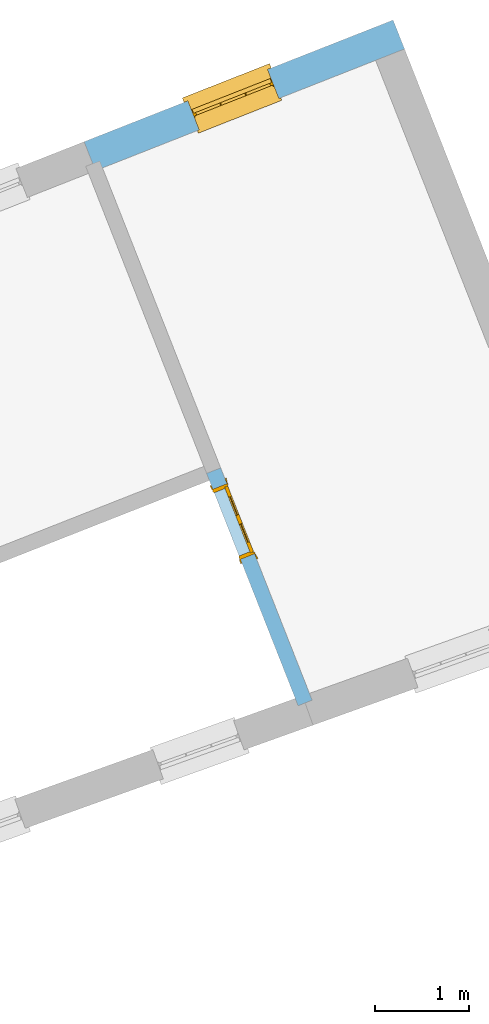
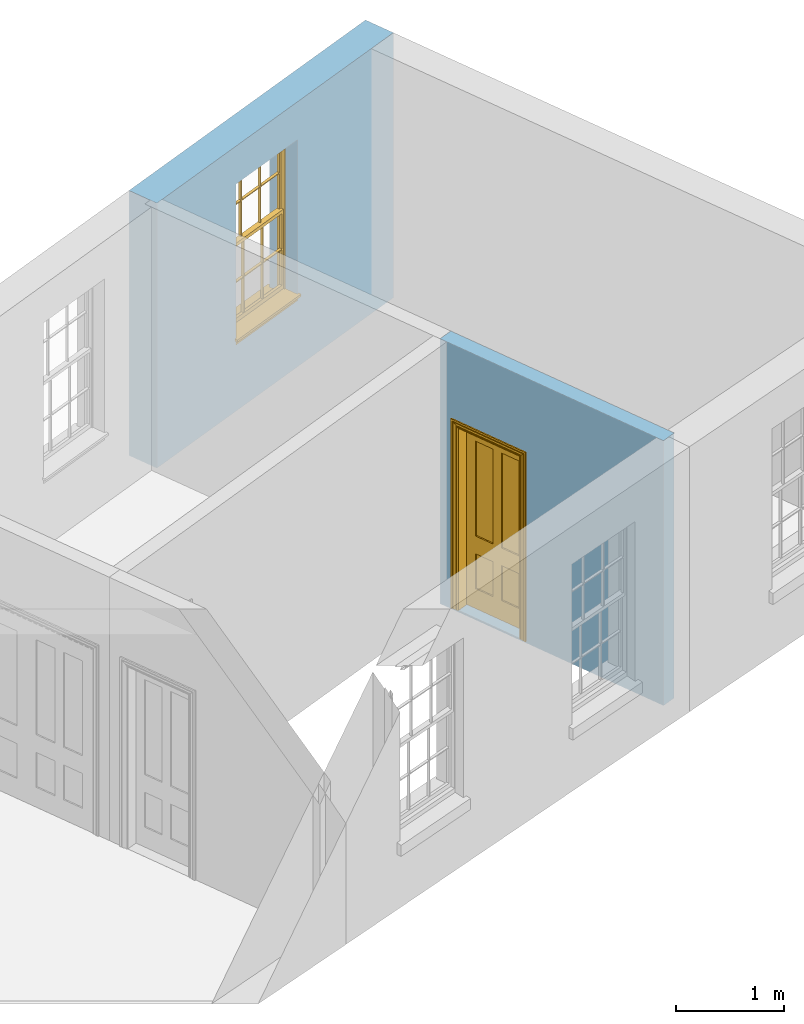
# One storey, part 6 of 6: 1 door, 1 window, 2 openings, plus 2 elements that do not belong to this part.
"""IFC2X3 building model written with IfcOpenShell, lengths in metres."""

from ifc_helpers import new_model, si_unit, frame, origin, place, context, subcontext, project, spatial, polyline, outline, extrude, faceted_brep, material, layer, layer_set, layer_usage, element, fill, save


model = new_model("IFC2X3")

# Units and contexts
model_context = context("Model", 3, world=origin())
body_context = subcontext(model_context, "Body", "Model", "MODEL_VIEW")
ifc_project = project(units=[si_unit("PLANEANGLEUNIT", "RADIAN"), si_unit("MASSUNIT", "GRAM", prefix="KILO"), si_unit("FORCEUNIT", "NEWTON", prefix="KILO"), si_unit("LENGTHUNIT", "METRE")], contexts=[model_context])

# Site, building, storey
site_placement = place(None, origin())
site = spatial("IfcSite", under=ifc_project, at=site_placement, CompositionType="ELEMENT")
building_placement = place(None, origin())
building = spatial("IfcBuilding", under=site, at=building_placement, Name="Building plot-4", CompositionType="ELEMENT")
storey_placement = place(None, frame((0.0, 0.0, 6.45)))
storey = spatial("IfcBuildingStorey", under=building, at=storey_placement, Name="Floor 1", CompositionType="ELEMENT", Elevation=6.45)

# Wall, opening, window
ifc_material_1 = material(Name="Masonry")
ifc_layer_1 = layer(ifc_material_1, 0.33, ventilated=False)
ifc_layer_set_1 = layer_set([ifc_layer_1], Name="My Wall")
ifc_layer_usage_1 = layer_usage(ifc_layer_set_1, "AXIS2", "NEGATIVE", 0.08)
wall_1_placement = place(storey_placement, origin())
wall_1 = element("IfcWallStandardCase", 1, at=wall_1_placement, inside=storey, material=ifc_layer_usage_1, Name="exterior", context=body_context, shape_type="SweptSolid", body=[
    extrude(outline(polyline([(55.3138387008242, 55.0638365529384), (55.192917321505, 55.3708838131828), (51.9157706887258, 54.0802776349957), (52.0366920680449, 53.7732303747513), (55.3138387008242, 55.0638365529384)])), origin(), (0.0, 0.0, 1.0), 3.0),
])
opening_1_placement = place(storey_placement, frame((0.0, 0.0, 0.75)))
opening_1 = element("IfcOpeningElement", 2, at=opening_1_placement, cuts=wall_1, Name="Opening", ObjectType="Opening", context=body_context, shape_type="SweptSolid", body=[
    extrude(outline(polyline([(53.8613912653598, 54.8465021034084), (53.0146851840799, 54.5130522392253), (53.1356065633991, 54.2060049789809), (53.9823126446789, 54.539454843164), (53.8613912653598, 54.8465021034084)])), origin(), (0.0, 0.0, 1.0), 1.82),
])
window_placement = place(storey_placement, frame((53.9529983709046, 54.6138905426172, 0.75), z_axis=(0.0, 0.0, 1.0), x_axis=(-0.846706081279848, -0.333449864183102, 0.0)))
window = element("IfcWindow", 3, at=window_placement, inside=storey, Name="bedroom outside window", OverallHeight=1.82, OverallWidth=0.91, context=body_context, shape_type="Brep", held_by="IfcProductRepresentation", body=[
    faceted_brep([(0.033125, -0.105, 0.975209), (0.01, -0.105, 0.975209), (0.033125, -0.105, 1.376042), (0.876875, -0.105, 0.975209), (0.876875, -0.105, 1.376042), (0.9, -0.105, 0.975209), (0.876875, -0.105, 1.386042), (0.876875, -0.105, 1.786875), (0.9, -0.105, 1.81), (0.033125, -0.105, 1.786875), (0.033125, -0.105, 1.386042), (0.01, -0.105, 1.81), (0.876875, -0.135, 1.376042), (0.876875, -0.135, 0.975209), (0.9, -0.135, 0.937083), (0.033125, -0.135, 1.786875), (0.01, -0.135, 1.81), (0.033125, -0.135, 1.386042), (0.01, -0.135, 0.937083), (0.033125, -0.135, 0.975209), (0.033125, -0.135, 1.376042), (0.876875, -0.135, 1.786875), (0.876875, -0.135, 1.386042), (0.9, -0.135, 1.81), (0.033125, -0.105, 0.937083), (0.01, -0.105, 0.937083), (0.033125, -0.105, 0.53625), (0.876875, -0.105, 0.937083), (0.876875, -0.105, 0.53625), (0.9, -0.105, 0.937083), (0.876875, -0.105, 0.52625), (0.876875, -0.105, 0.125417), (0.9, -0.105, 0.077167), (0.033125, -0.105, 0.125417), (0.033125, -0.105, 0.52625), (0.01, -0.105, 0.077167), (-0.0425, -0.25, 0.01), (-0.0425, -0.3, 0.001667), (0.0, -0.25, 0.01), (0.9525, -0.25, 0.01), (0.91, -0.25, 0.01), (0.9525, -0.3, 0.001667), (-0.02, 0.08, 0.077167), (0.0, 0.08, 0.077167), (-0.02, 0.11, 0.077167), (0.0, -0.06, 0.077167), (0.01, -0.06, 0.077167), (0.91, -0.06, 0.077167), (0.91, 0.08, 0.077167), (0.9, -0.06, 0.077167), (0.93, 0.08, 0.077167), (0.93, 0.11, 0.077167), (0.01, -0.075, 0.975209), (0.9, -0.075, 0.975209), (0.876875, -0.075, 0.125417), (0.876875, -0.075, 0.52625), (0.9, -0.075, 0.077167), (0.876875, -0.075, 0.53625), (0.876875, -0.075, 0.937083), (0.033125, -0.075, 0.125417), (0.01, -0.075, 0.077167), (0.033125, -0.075, 0.52625), (0.033125, -0.075, 0.937083), (0.033125, -0.075, 0.53625), (-0.02, 0.08, 0.052167), (-0.02, 0.11, 0.052167), (0.93, 0.11, 0.052167), (0.93, 0.08, 0.052167), (0.91, 0.08, 0.052167), (0.0, 0.08, 0.052167), (0.91, -0.15, 0.026667), (0.0, -0.15, 0.026667), (-0.0425, -0.3, -0.123333), (0.9525, -0.3, -0.123333), (-0.0425, -0.25, -0.123333), (0.9525, -0.25, -0.123333), (0.01, -0.06, 1.81), (0.9, -0.06, 1.81), (0.0, -0.06, 1.82), (0.91, -0.06, 1.82), (0.01, -0.15, 0.077167), (0.9, -0.15, 0.077167), (0.592292, -0.105, 0.125417), (0.592292, -0.075, 0.125417), (0.317708, -0.075, 0.125417), (0.317708, -0.105, 0.125417), (0.592292, -0.105, 0.53625), (0.317708, -0.105, 0.53625), (0.317708, -0.105, 0.52625), (0.592292, -0.105, 0.52625), (0.592292, -0.075, 0.53625), (0.317708, -0.075, 0.53625), (0.592292, -0.135, 1.386042), (0.592292, -0.105, 1.386042), (0.317708, -0.105, 1.386042), (0.317708, -0.135, 1.386042), (0.317708, -0.135, 1.376042), (0.592292, -0.135, 1.376042), (0.317708, -0.105, 1.376042), (0.592292, -0.105, 1.376042), (0.602292, -0.135, 1.376042), (0.592292, -0.135, 0.975209), (0.602292, -0.135, 0.975209), (0.602292, -0.105, 0.975209), (0.592292, -0.105, 0.975209), (0.602292, -0.105, 1.376042), (0.602292, -0.075, 0.53625), (0.602292, -0.105, 0.53625), (0.317708, -0.075, 0.52625), (0.307708, -0.075, 0.125417), (0.307708, -0.075, 0.52625), (0.602292, -0.075, 0.52625), (0.602292, -0.075, 0.125417), (0.592292, -0.075, 0.52625), (0.307708, -0.075, 0.53625), (0.317708, -0.075, 0.937083), (0.307708, -0.075, 0.937083), (0.602292, -0.075, 0.937083), (0.592292, -0.075, 0.937083), (0.307708, -0.105, 0.52625), (0.307708, -0.105, 0.125417), (0.307708, -0.105, 0.53625), (0.307708, -0.105, 0.937083), (0.592292, -0.105, 0.937083), (0.317708, -0.105, 0.937083), (0.602292, -0.105, 0.937083), (0.602292, -0.105, 0.52625), (0.602292, -0.105, 0.125417), (0.307708, -0.135, 1.386042), (0.307708, -0.135, 1.376042), (0.307708, -0.135, 0.975209), (0.317708, -0.135, 0.975209), (0.317708, -0.135, 1.786875), (0.307708, -0.135, 1.786875), (0.602292, -0.135, 1.786875), (0.592292, -0.135, 1.786875), (0.602292, -0.135, 1.386042), (0.602292, -0.105, 1.386042), (0.307708, -0.105, 1.386042), (0.307708, -0.105, 1.786875), (0.317708, -0.105, 1.786875), (0.592292, -0.105, 1.786875), (0.602292, -0.105, 1.786875), (0.307708, -0.105, 1.376042), (0.317708, -0.105, 0.975209), (0.307708, -0.105, 0.975209), (0.91, -0.15, 1.82), (0.9, -0.15, 1.81), (0.01, -0.15, 1.81), (0.0, -0.15, 1.82), (0.91, -0.25, 0.0), (0.0, -0.25, 0.0), (0.91, 0.08, 0.0), (0.0, 0.08, 0.0)], [[[0, 1, 2]], [[3, 4, 5]], [[6, 7, 8]], [[9, 10, 11]], [[12, 13, 14]], [[15, 16, 17]], [[18, 19, 20]], [[21, 22, 23]], [[24, 25, 26]], [[27, 28, 29]], [[30, 31, 32]], [[33, 34, 35]], [[14, 27, 29]], [[25, 24, 18]], [[36, 37, 38]], [[39, 40, 41]], [[42, 43, 44]], [[45, 46, 43]], [[47, 48, 49]], [[50, 51, 48]], [[1, 0, 52]], [[5, 53, 3]], [[54, 55, 56]], [[57, 58, 53]], [[59, 60, 61]], [[62, 63, 52]], [[48, 43, 46, 49]], [[51, 44, 43, 48]], [[64, 42, 44, 65]], [[65, 44, 51, 66]], [[66, 51, 50, 67]], [[65, 66, 68, 69]], [[60, 56, 49, 46]], [[70, 71, 38, 40]], [[37, 41, 40, 38]], [[37, 72, 73, 41]], [[74, 75, 73, 72]], [[8, 11, 76, 77]], [[76, 78, 79, 77]], [[32, 35, 80, 81]], [[81, 80, 71, 70]], [[82, 83, 84, 85]], [[86, 87, 88, 89]], [[86, 90, 91, 87]], [[92, 93, 94, 95]], [[92, 95, 96, 97]], [[96, 98, 99, 97]], [[100, 97, 101, 102]], [[103, 104, 99, 105]], [[97, 99, 104, 101]], [[102, 103, 105, 100]], [[28, 57, 106, 107]], [[108, 84, 109, 110]], [[111, 112, 83, 113]], [[114, 110, 61, 63]], [[90, 113, 108, 91]], [[115, 91, 114, 116]], [[117, 106, 90, 118]], [[111, 106, 57, 55]], [[119, 110, 109, 120]], [[34, 61, 110, 119]], [[89, 113, 83, 82]], [[88, 108, 113, 89]], [[85, 84, 108, 88]], [[121, 114, 63, 26]], [[122, 116, 114, 121]], [[123, 118, 90, 86]], [[87, 91, 115, 124]], [[107, 106, 117, 125]], [[126, 111, 55, 30]], [[127, 112, 111, 126]], [[126, 30, 28, 107]], [[88, 119, 120, 85]], [[126, 89, 82, 127]], [[125, 123, 86, 107]], [[121, 26, 34, 119]], [[124, 122, 121, 87]], [[128, 17, 20, 129]], [[96, 129, 130, 131]], [[132, 133, 128, 95]], [[134, 135, 92, 136]], [[100, 12, 22, 136]], [[137, 6, 4, 105]], [[94, 138, 139, 140]], [[137, 93, 141, 142]], [[99, 98, 94, 93]], [[143, 2, 10, 138]], [[144, 145, 143, 98]], [[129, 143, 145, 130]], [[20, 2, 143, 129]], [[131, 144, 98, 96]], [[128, 138, 10, 17]], [[133, 139, 138, 128]], [[135, 141, 93, 92]], [[95, 94, 140, 132]], [[22, 6, 137, 136]], [[136, 137, 142, 134]], [[100, 105, 4, 12]], [[107, 86, 89, 126]], [[106, 111, 113, 90]], [[91, 108, 110, 114]], [[87, 121, 119, 88]], [[97, 100, 136, 92]], [[129, 96, 95, 128]], [[98, 143, 138, 94]], [[105, 99, 93, 137]], [[131, 101, 104, 144]], [[124, 115, 118, 123]], [[132, 140, 141, 135]], [[120, 109, 59, 33]], [[15, 9, 139, 133]], [[134, 142, 7, 21]], [[31, 54, 112, 127]], [[36, 74, 72, 37]], [[39, 41, 73, 75]], [[18, 14, 101, 131]], [[23, 16, 132, 135]], [[83, 56, 60, 84]], [[52, 53, 118, 115]], [[53, 52, 144, 104]], [[11, 8, 141, 140]], [[14, 18, 124, 123]], [[2, 1, 11, 10]], [[8, 5, 4, 6]], [[57, 53, 56, 55]], [[60, 52, 63, 61]], [[26, 25, 35, 34]], [[32, 29, 28, 30]], [[14, 23, 22, 12]], [[18, 20, 17, 16]], [[19, 0, 2, 20]], [[17, 10, 9, 15]], [[12, 4, 3, 13]], [[21, 7, 6, 22]], [[27, 58, 57, 28]], [[30, 55, 54, 31]], [[33, 59, 61, 34]], [[26, 63, 62, 24]], [[5, 8, 77, 53]], [[76, 11, 1, 52]], [[46, 45, 78, 76]], [[49, 77, 79, 47]], [[70, 146, 147, 81]], [[71, 80, 148, 149]], [[19, 130, 145, 0]], [[102, 13, 3, 103]], [[116, 122, 24, 62]], [[29, 32, 81, 14]], [[80, 35, 25, 18]], [[60, 46, 76, 52]], [[77, 49, 56, 53]], [[23, 14, 81, 147]], [[16, 148, 80, 18]], [[35, 85, 120]], [[120, 33, 35]], [[127, 82, 32]], [[32, 31, 127]], [[32, 82, 85, 35]], [[102, 101, 14]], [[14, 13, 102]], [[18, 131, 130]], [[130, 19, 18]], [[134, 21, 23]], [[23, 135, 134]], [[16, 15, 133]], [[133, 132, 16]], [[11, 140, 139]], [[139, 9, 11]], [[142, 141, 8]], [[8, 7, 142]], [[23, 147, 148, 16]], [[146, 149, 148, 147]], [[52, 115, 116]], [[116, 62, 52]], [[118, 53, 117]], [[58, 117, 53]], [[27, 125, 117, 58]], [[56, 83, 112]], [[112, 54, 56]], [[109, 84, 60]], [[60, 59, 109]], [[125, 27, 14]], [[14, 123, 125]], [[122, 124, 18]], [[18, 24, 122]], [[145, 144, 52]], [[52, 0, 145]], [[103, 3, 53]], [[53, 104, 103]], [[79, 78, 149, 146]], [[78, 45, 71, 149]], [[146, 70, 47, 79]], [[150, 75, 74, 151]], [[68, 66, 67]], [[48, 68, 67, 50]], [[69, 64, 65]], [[42, 64, 69, 43]], [[69, 68, 152, 153]], [[70, 68, 48, 47]], [[150, 152, 68, 70]], [[43, 69, 71, 45]], [[69, 153, 151, 71]], [[152, 150, 151, 153]], [[38, 151, 74, 36]], [[71, 151, 38]], [[39, 75, 150, 40]], [[40, 150, 70]]]),
])
fill(opening_1, window)

# Wall, opening, door
ifc_material_2 = material(Name="Masonry")
ifc_layer_2 = layer(ifc_material_2, 0.16, ventilated=False)
ifc_layer_set_2 = layer_set([ifc_layer_2], Name="My Wall")
ifc_layer_usage_2 = layer_usage(ifc_layer_set_2, "AXIS2", "NEGATIVE", 0.08)
wall_2_placement = place(storey_placement, origin())
wall_2 = element("IfcWallStandardCase", 4, at=wall_2_placement, inside=storey, material=ifc_layer_usage_2, Name="interior", context=body_context, shape_type="SweptSolid", body=[
    extrude(outline(polyline([(53.3639971862187, 50.6212203481571), (53.2151257873123, 50.5625918006085), (54.1850919906856, 48.0996239867093), (54.333963389592, 48.1582525342579), (53.3639971862187, 50.6212203481571)])), origin(), (0.0, 0.0, 1.0), 3.0),
])
opening_2_placement = place(storey_placement, frame((0.0, 0.0, 0.0199999999999996)))
opening_2 = element("IfcOpeningElement", 5, at=opening_2_placement, cuts=wall_2, Name="Opening", ObjectType="Opening", context=body_context, shape_type="SweptSolid", body=[
    extrude(outline(polyline([(53.2810829033046, 50.3951114768388), (53.574225641048, 49.6507544823071), (53.7230970399543, 49.7093830298558), (53.4299543022109, 50.4537400243875), (53.2810829033046, 50.3951114768388)])), origin(), (0.0, 0.0, 1.0), 2.1),
])
door_placement = place(storey_placement, frame((53.3555186027578, 50.4244257506132, 0.0199999999999996), z_axis=(0.0, 0.0, 1.0), x_axis=(0.293142737743402, -0.744356994531721, 0.0)))
door = element("IfcDoor", 6, at=door_placement, inside=storey, Name="bedroom inside door", OverallHeight=2.1, OverallWidth=0.8, context=body_context, shape_type="Brep", held_by="IfcProductRepresentation", body=[
    faceted_brep([(0.773, 0.08, 1.895), (0.66, 0.08, 1.895), (0.66, 0.08, 2.073), (0.773, 0.08, 2.073), (0.773, 0.08, 0.82), (0.66, 0.08, 0.82), (0.45, 0.08, 1.895), (0.45, 0.08, 2.073), (0.773, 0.08, 0.62), (0.66, 0.08, 0.62), (0.66, 0.065, 0.82), (0.66, 0.065, 1.895), (0.45, 0.065, 1.895), (0.35, 0.08, 1.895), (0.35, 0.08, 2.073), (0.773, 0.08, 0.225), (0.66, 0.08, 0.225), (0.45, 0.08, 0.62), (0.45, 0.08, 0.82), (0.45, 0.065, 0.82), (0.35, 0.08, 0.82), (0.14, 0.08, 2.073), (0.14, 0.08, 1.895), (0.773, 0.08, 0.0), (0.66, 0.08, 0.0), (0.66, 0.065, 0.225), (0.66, 0.065, 0.62), (0.45, 0.065, 0.62), (0.35, 0.08, 0.62), (0.35, 0.065, 0.82), (0.35, 0.065, 1.895), (0.14, 0.065, 1.895), (0.027, 0.08, 2.073), (0.027, 0.08, 1.895), (0.773, 0.042, 0.0), (0.66, 0.042, 0.0), (0.45, 0.08, 0.0), (0.45, 0.08, 0.225), (0.45, 0.065, 0.225), (0.35, 0.08, 0.225), (0.14, 0.08, 0.82), (0.14, 0.08, 0.62), (0.14, 0.065, 0.82), (0.027, 0.08, 0.82), (0.773, 0.042, 0.225), (0.66, 0.042, 0.225), (0.45, 0.042, 0.0), (0.35, 0.08, 0.0), (0.35, 0.065, 0.225), (0.35, 0.065, 0.62), (0.14, 0.065, 0.62), (0.027, 0.08, 0.62), (0.773, 0.042, 0.62), (0.66, 0.042, 0.62), (0.45, 0.042, 0.225), (0.35, 0.042, 0.0), (0.14, 0.08, 0.225), (0.14, 0.08, 0.0), (0.14, 0.065, 0.225), (0.027, 0.08, 0.225), (0.773, 0.042, 0.82), (0.66, 0.042, 0.82), (0.66, 0.057, 0.62), (0.66, 0.057, 0.225), (0.45, 0.057, 0.225), (0.35, 0.042, 0.225), (0.14, 0.042, 0.0), (0.027, 0.08, 0.0), (0.773, 0.042, 1.895), (0.66, 0.042, 1.895), (0.45, 0.042, 0.62), (0.45, 0.042, 0.82), (0.45, 0.057, 0.62), (0.35, 0.042, 0.62), (0.14, 0.042, 0.225), (0.027, 0.042, 0.0), (0.773, 0.042, 2.073), (0.66, 0.042, 2.073), (0.66, 0.057, 1.895), (0.66, 0.057, 0.82), (0.45, 0.057, 0.82), (0.35, 0.042, 0.82), (0.35, 0.057, 0.62), (0.35, 0.057, 0.225), (0.14, 0.057, 0.225), (0.027, 0.042, 0.225), (0.45, 0.042, 1.895), (0.45, 0.042, 2.073), (0.45, 0.057, 1.895), (0.35, 0.042, 1.895), (0.14, 0.042, 0.82), (0.14, 0.042, 0.62), (0.14, 0.057, 0.62), (0.027, 0.042, 0.62), (0.35, 0.042, 2.073), (0.35, 0.057, 1.895), (0.35, 0.057, 0.82), (0.14, 0.057, 0.82), (0.027, 0.042, 0.82), (0.14, 0.042, 2.073), (0.14, 0.042, 1.895), (0.14, 0.057, 1.895), (0.027, 0.042, 1.895), (0.027, 0.042, 2.073), (0.02, 0.085, 0.0), (0.005, 0.09, 0.0), (0.005, 0.09, 2.095), (0.02, 0.085, 2.08), (0.02, 0.08, 0.0), (0.0, 0.085, 0.0), (0.0, 0.085, 2.1), (0.795, 0.09, 2.095), (0.78, 0.085, 2.08), (0.02, 0.08, 2.08), (0.0, 0.08, 0.0), (-0.032, 0.095, 0.0), (-0.032, 0.095, 2.132), (0.8, 0.085, 2.1), (0.795, 0.09, 0.0), (0.78, 0.085, 0.0), (0.78, 0.08, 2.08), (0.04, 0.04, 0.0), (0.025, 0.04, 0.0), (0.025, 0.04, 2.075), (0.04, 0.04, 2.06), (-0.04, 0.09, 0.0), (-0.04, 0.09, 2.14), (0.832, 0.095, 2.132), (0.8, 0.085, 0.0), (0.78, 0.08, 0.0), (0.8, 0.08, 0.0), (0.86, 0.08, 0.0), (0.86, 0.08, 2.16), (0.8, 0.08, 2.1), (-0.06, 0.08, 2.16), (0.0, 0.08, 2.1), (-0.06, 0.08, 0.0), (-0.04, 0.095, 0.0), (-0.04, 0.095, 2.14), (0.84, 0.09, 2.14), (0.832, 0.095, 0.0), (0.84, 0.09, 0.0), (0.86, 0.095, 0.0), (0.86, 0.095, 2.16), (-0.06, 0.095, 2.16), (-0.06, 0.095, 0.0), (0.84, 0.095, 0.0), (0.84, 0.095, 2.14), (-0.025, -0.095, 0.0), (-0.025, -0.09, 0.0), (-0.025, -0.09, 2.125), (-0.025, -0.095, 2.125), (-0.017, -0.095, 0.0), (-0.017, -0.095, 2.117), (0.825, -0.09, 2.125), (0.825, -0.095, 2.125), (0.825, -0.095, 0.0), (0.845, -0.095, 0.0), (-0.045, -0.095, 2.145), (-0.045, -0.095, 0.0), (0.845, -0.095, 2.145), (0.015, -0.085, 0.0), (0.015, -0.085, 2.085), (0.817, -0.095, 2.117), (0.825, -0.09, 0.0), (0.845, -0.08, 0.0), (0.845, -0.08, 2.145), (-0.045, -0.08, 2.145), (-0.045, -0.08, 0.0), (0.02, -0.09, 0.0), (0.02, -0.09, 2.08), (0.785, -0.085, 2.085), (0.817, -0.095, 0.0), (0.8, -0.08, 0.0), (0.8, -0.08, 2.1), (0.0, -0.08, 2.1), (0.0, -0.08, 0.0), (0.035, -0.085, 0.0), (0.035, -0.085, 2.065), (0.78, -0.09, 2.08), (0.785, -0.085, 0.0), (0.775, 0.04, 2.075), (0.76, 0.04, 2.06), (0.035, -0.08, 2.065), (0.035, -0.08, 0.0), (0.765, -0.085, 2.065), (0.78, -0.09, 0.0), (0.765, -0.08, 0.0), (0.765, -0.08, 2.065), (0.765, -0.085, 0.0), (0.04, -0.08, 2.06), (0.04, -0.08, 0.0), (0.76, -0.08, 2.06), (0.76, -0.08, 0.0), (0.76, 0.04, 0.0), (0.775, 0.04, 0.0), (0.025, 0.08, 0.0), (0.025, 0.08, 2.075), (0.775, 0.08, 0.0), (0.775, 0.08, 2.075)], [[[0, 1, 2, 3]], [[1, 0, 4, 5]], [[1, 6, 7, 2]], [[8, 9, 5, 4]], [[1, 5, 10, 11]], [[6, 1, 11, 12]], [[6, 13, 14, 7]], [[15, 16, 9, 8]], [[9, 17, 18, 5]], [[5, 18, 19, 10]], [[10, 19, 12, 11]], [[18, 6, 12, 19]], [[18, 20, 13, 6]], [[21, 14, 13, 22]], [[23, 24, 16, 15]], [[9, 16, 25, 26]], [[17, 9, 26, 27]], [[17, 28, 20, 18]], [[13, 20, 29, 30]], [[22, 13, 30, 31]], [[32, 21, 22, 33]], [[34, 35, 24, 23]], [[24, 36, 37, 16]], [[16, 37, 38, 25]], [[25, 38, 27, 26]], [[37, 17, 27, 38]], [[37, 39, 28, 17]], [[40, 20, 28, 41]], [[20, 40, 42, 29]], [[31, 30, 29, 42]], [[40, 22, 31, 42]], [[33, 22, 40, 43]], [[35, 34, 44, 45]], [[35, 46, 36, 24]], [[36, 47, 39, 37]], [[28, 39, 48, 49]], [[41, 28, 49, 50]], [[43, 40, 41, 51]], [[45, 44, 52, 53]], [[46, 35, 45, 54]], [[46, 55, 47, 36]], [[56, 39, 47, 57]], [[39, 56, 58, 48]], [[50, 49, 48, 58]], [[56, 41, 50, 58]], [[51, 41, 56, 59]], [[53, 52, 60, 61]], [[45, 53, 62, 63]], [[54, 45, 63, 64]], [[55, 46, 54, 65]], [[55, 66, 57, 47]], [[59, 56, 57, 67]], [[61, 60, 68, 69]], [[70, 53, 61, 71]], [[53, 70, 72, 62]], [[72, 64, 63, 62]], [[70, 54, 64, 72]], [[65, 54, 70, 73]], [[65, 74, 66, 55]], [[67, 57, 66, 75]], [[69, 68, 76, 77]], [[61, 69, 78, 79]], [[71, 61, 79, 80]], [[73, 70, 71, 81]], [[65, 73, 82, 83]], [[74, 65, 83, 84]], [[74, 85, 75, 66]], [[86, 69, 77, 87]], [[69, 86, 88, 78]], [[88, 80, 79, 78]], [[86, 71, 80, 88]], [[81, 71, 86, 89]], [[73, 81, 90, 91]], [[73, 91, 92, 82]], [[83, 82, 92, 84]], [[91, 74, 84, 92]], [[91, 93, 85, 74]], [[89, 86, 87, 94]], [[81, 89, 95, 96]], [[90, 81, 96, 97]], [[90, 98, 93, 91]], [[94, 99, 100, 89]], [[89, 100, 101, 95]], [[101, 97, 96, 95]], [[100, 90, 97, 101]], [[100, 102, 98, 90]], [[99, 103, 102, 100]], [[32, 103, 99, 21]], [[102, 103, 32, 33]], [[98, 102, 33, 43]], [[21, 99, 94, 14]], [[94, 87, 7, 14]], [[7, 87, 77, 2]], [[76, 3, 2, 77]], [[43, 51, 93, 98]], [[51, 59, 85, 93]], [[67, 75, 85, 59]], [[34, 23, 15, 44]], [[44, 15, 8, 52]], [[52, 8, 4, 60]], [[0, 68, 60, 4]], [[0, 3, 76, 68]], [[104, 105, 106, 107]], [[104, 108, 109, 105]], [[105, 109, 110, 106]], [[107, 106, 111, 112]], [[107, 113, 108, 104]], [[114, 109, 108]], [[109, 115, 116, 110]], [[106, 110, 117, 111]], [[112, 111, 118, 119]], [[113, 107, 112, 120]], [[121, 122, 123, 124]], [[115, 109, 114, 125]], [[115, 125, 126, 116]], [[110, 116, 127, 117]], [[111, 117, 128, 118]], [[118, 128, 129, 119]], [[120, 112, 119, 129]], [[130, 129, 128]], [[130, 131, 132, 133]], [[133, 132, 134, 135]], [[135, 134, 136, 114]], [[136, 125, 114]], [[125, 137, 138, 126]], [[116, 126, 139, 127]], [[117, 127, 140, 128]], [[141, 130, 128, 140]], [[131, 130, 141]], [[131, 142, 143, 132]], [[132, 143, 144, 134]], [[134, 144, 145, 136]], [[137, 125, 136, 145]], [[143, 142, 146]], [[143, 146, 147]], [[137, 145, 144]], [[143, 147, 138]], [[138, 137, 144]], [[143, 138, 144]], [[126, 138, 147, 139]], [[127, 139, 141, 140]], [[142, 131, 141, 146]], [[139, 147, 146, 141]], [[148, 149, 150, 151]], [[149, 152, 153, 150]], [[151, 150, 154, 155]], [[155, 156, 157]], [[158, 159, 148]], [[158, 148, 151]], [[155, 157, 160]], [[158, 151, 155]], [[155, 160, 158]], [[152, 161, 162, 153]], [[150, 153, 163, 154]], [[155, 154, 164, 156]], [[156, 164, 165, 157]], [[157, 165, 166, 160]], [[160, 166, 167, 158]], [[158, 167, 168, 159]], [[161, 169, 170, 162]], [[153, 162, 171, 163]], [[154, 163, 172, 164]], [[165, 164, 173]], [[165, 173, 174, 166]], [[166, 174, 175, 167]], [[167, 175, 176, 168]], [[169, 177, 178, 170]], [[162, 170, 179, 171]], [[163, 171, 180, 172]], [[172, 180, 173, 164]], [[124, 123, 181, 182]], [[183, 178, 177, 184]], [[170, 178, 185, 179]], [[171, 179, 186, 180]], [[187, 173, 180]], [[185, 188, 187, 189]], [[188, 185, 178, 183]], [[179, 185, 189, 186]], [[189, 187, 180, 186]], [[190, 183, 184, 191]], [[192, 188, 183, 190]], [[191, 184, 122, 121]], [[124, 190, 191, 121]], [[193, 187, 188, 192]], [[182, 192, 190, 124]], [[184, 176, 122]], [[194, 195, 187, 193]], [[192, 182, 194, 193]], [[161, 176, 184]], [[114, 108, 122, 176]], [[173, 187, 195]], [[152, 149, 176, 161]], [[169, 161, 184, 177]], [[196, 122, 108]], [[176, 175, 135, 114]], [[173, 195, 129, 130]], [[176, 149, 168]], [[123, 122, 196, 197]], [[196, 108, 113, 197]], [[175, 174, 133, 135]], [[198, 129, 195]], [[133, 174, 173, 130]], [[159, 168, 149, 148]], [[181, 123, 197, 199]], [[197, 113, 120, 199]], [[199, 120, 129, 198]], [[195, 181, 199, 198]], [[195, 194, 182, 181]]]),
])
fill(opening_2, door)

save(model, "model.ifc")
